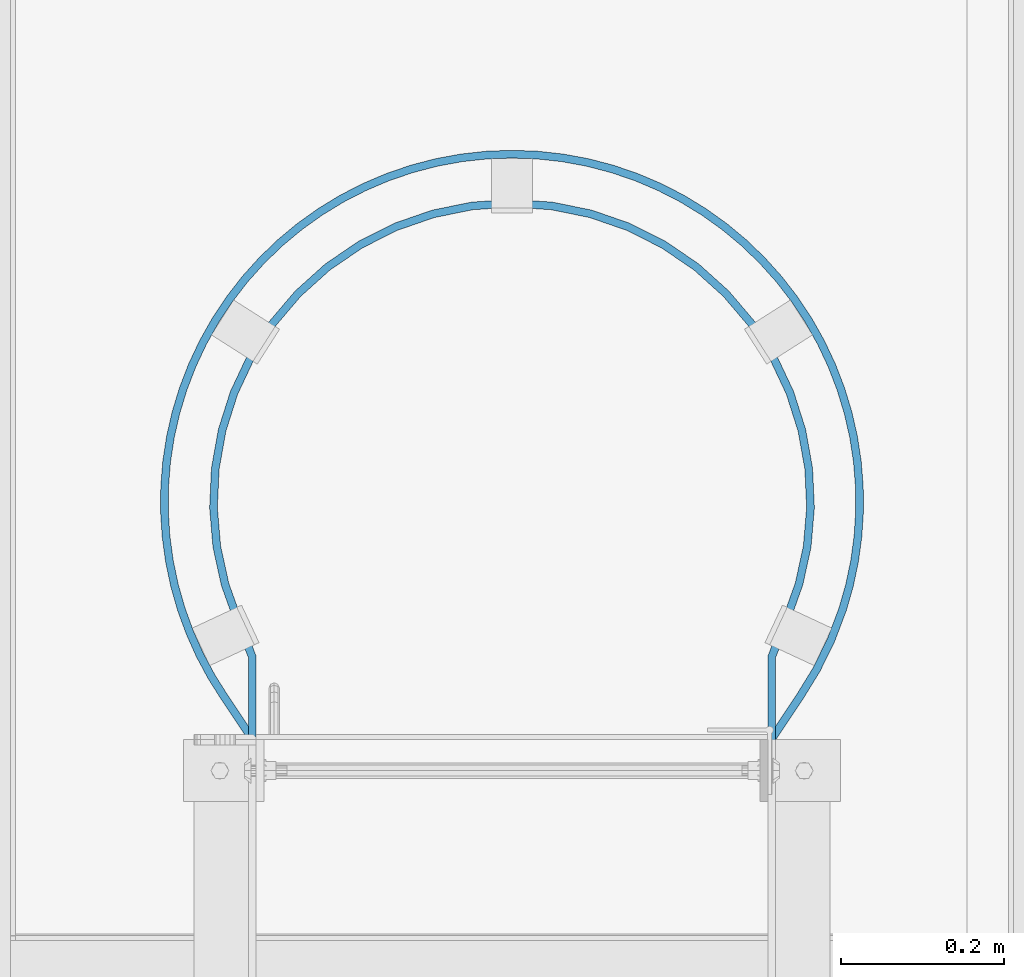
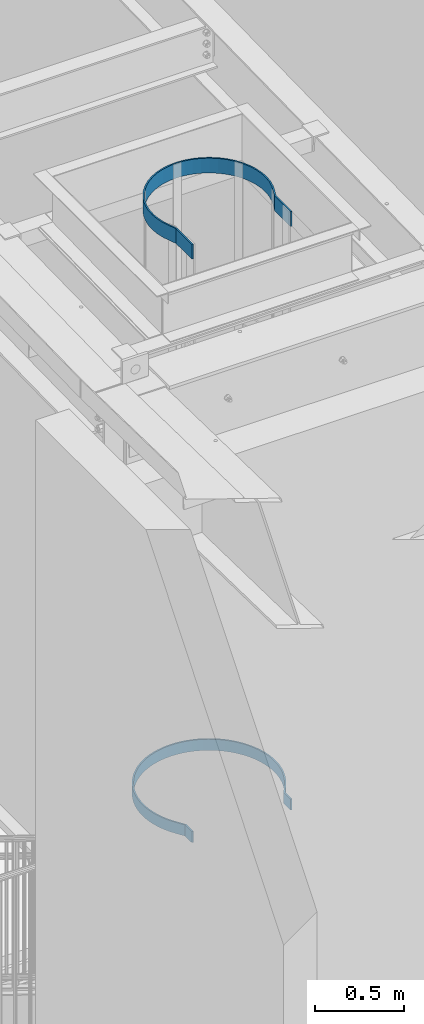
# One storey, part 1078 of 1763: 2 beams, 1 element without a shape of its own.
"""IFC2X3 building model written with IfcOpenShell, lengths in millimetres."""

from ifc_helpers import new_model, si_unit, frame, origin_with_axes, place, context, subcontext, project, spatial, faceted_brep, material, type_object, element, aggregate, save


model = new_model("IFC2X3")

# Units and contexts
model_context = context("Model", 3, precision=1e-05, world=origin_with_axes())
body_context = subcontext(model_context, "Body", "Model", "MODEL_VIEW")
ifc_project = project(units=[si_unit("LENGTHUNIT", "METRE", prefix="MILLI"), si_unit("AREAUNIT", "SQUARE_METRE"), si_unit("VOLUMEUNIT", "CUBIC_METRE"), si_unit("MASSUNIT", "GRAM", prefix="KILO"), si_unit("TIMEUNIT", "SECOND"), si_unit("PLANEANGLEUNIT", "RADIAN"), si_unit("SOLIDANGLEUNIT", "STERADIAN"), si_unit("THERMODYNAMICTEMPERATUREUNIT", "DEGREE_CELSIUS"), si_unit("LUMINOUSINTENSITYUNIT", "LUMEN")], contexts=[model_context])

# Site, building, storey
site_placement = place(None, origin_with_axes())
site = spatial("IfcSite", under=ifc_project, at=site_placement, CompositionType="ELEMENT")
building_placement = place(site_placement, origin_with_axes())
building = spatial("IfcBuilding", under=site, at=building_placement, Name="Undefined", CompositionType="ELEMENT")
storey_placement = place(building_placement, origin_with_axes())
storey = spatial("IfcBuildingStorey", under=building, at=storey_placement, Name="Undefined", CompositionType="ELEMENT", Elevation=0.0)

# Assembly, beams
assembly_placement = place(storey_placement, origin_with_axes())
assembly = element("IfcElementAssembly", 1, at=assembly_placement, inside=storey, Name="LADDER", AssemblyPlace="NOTDEFINED", PredefinedType="RIGID_FRAME")
ifc_material = material(Name="STEEL/A36")
beam_type_1 = type_object("IfcBeamType", PredefinedType="NOTDEFINED")
beam_1_placement = place(assembly_placement, frame((-86091.1497736991, 30492.7, 7658.1), z_axis=(0.0, 0.0, 1.0), x_axis=(0.0, 1.0, 0.0)))
beam_1 = element("IfcBeam", 2, at=beam_1_placement, type_object=beam_type_1, material=ifc_material, Name="PLATE", context=body_context, shape_type="Brep", body=[
    faceted_brep([(0.0, -4.76249999999709, -38.1000000000004), (0.0, -4.76249999999709, 38.1000000000004), (0.0, 4.76249999999709, 38.1000000000004), (0.0, 4.76249999999709, -38.1000000000004), (78.8281400921587, 4.76249999999709, 38.1000000000004), (78.8281400921587, 4.76249999999709, -38.1000000000004), (75.9319917437788, -4.76249999999709, -38.1000000000004), (75.9319917437788, -4.76249999999709, 38.1000000000004), (82.4725334546747, 2.32052630072576, -38.1000000000004), (82.4725334546747, 2.32052630072576, 38.1000000000004), (130.23712785008, -29.6849795318849, 38.1000000000004), (130.23712785008, -29.6849795318849, -38.1000000000004), (77.1704222683657, -5.59232665935997, 38.1000000000004), (77.1704222683657, -5.59232665935997, -38.1000000000004), (124.867288043475, -37.5520276092284, -38.1000000000004), (124.867288043475, -37.5520276092284, 38.1000000000004), (164.34760181994, -50.6686286850454, 38.1000000000004), (164.34760181994, -50.6686286850454, -38.1000000000004), (159.747171460254, -59.0089923165506, -38.1000000000004), (159.747171460254, -59.0089923165506, 38.1000000000004), (196.502852637441, -77.065224005928, -38.1000000000004), (196.502852637441, -77.065224005928, 38.1000000000004), (200.292495644782, -68.3265610145463, 38.1000000000004), (200.292495644782, -68.3265610145463, -38.1000000000004), (234.803737917307, -91.5583185132127, -38.1000000000004), (234.803737917307, -91.5583185132127, 38.1000000000004), (237.748508176443, -82.499954802217, 38.1000000000004), (237.748508176443, -82.499954802217, -38.1000000000004), (266.714984550341, -90.7864578098379, 38.1000000000004), (266.714984550341, -90.7864578098379, -38.1000000000004), (264.42359242673, -100.031734827629, -38.1000000000004), (264.42359242673, -100.031734827629, 38.1000000000004), (294.572231675724, -106.371617841563, -38.1000000000004), (294.572231675724, -106.371617841563, 38.1000000000004), (296.198581312558, -96.9864906789444, 38.1000000000004), (296.198580994936, -96.9864906238945, -38.1000000000004), (326.253675137221, -101.08899552701, 38.1000000000004), (326.253675137221, -101.08899552701, -38.1000000000004), (325.305262653088, -110.566660785917, -38.1000000000004), (325.305262653088, -110.566660785917, 38.1000000000004), (356.260153345538, -112.544614423969, -38.1000000000004), (356.260153345538, -112.544614423969, 38.1000000000004), (356.525735326341, -103.023317704952, 38.1000000000004), (356.52573594483, -103.023317722196, -38.1000000000004), (386.858539739838, -102.77948519589, 38.1000000000004), (386.858539739838, -102.77948519589, -38.1000000000004), (387.277154065716, -112.295281906947, -38.1000000000004), (387.277154065716, -112.295281906947, 38.1000000000004), (418.19623042244, -109.81995243681, -38.1000000000004), (418.19623042244, -109.81995243681, 38.1000000000004), (417.095578659591, -100.35875850069, 38.1000000000004), (417.095578199151, -100.358758554255, -38.1000000000004), (447.080825926212, -95.773625916685, 38.1000000000004), (447.080825926212, -95.773625916685, -38.1000000000004), (448.857836479659, -105.13139586967, -38.1000000000004), (448.857836479659, -105.13139586967, 38.1000000000004), (479.103752236508, -98.2538090848248, -38.1000000000004), (479.103752236508, -98.2538090848248, 38.1000000000004), (476.659553427558, -89.0477503634029, 38.1000000000004), (476.659553185309, -89.0477504277223, -38.1000000000004), (505.679144955247, -80.2158283481549, 38.1000000000004), (505.679144955247, -80.2158283481549, -38.1000000000004), (508.777922306675, -89.2226704099594, -38.1000000000004), (508.777922306675, -89.2226704099594, 38.1000000000004), (537.727203103354, -78.0845843564894, -38.1000000000004), (537.727203103354, -78.0845843564894, 38.1000000000004), (533.989837912271, -69.3234356630419, 38.1000000000004), (533.989838241414, -69.323435522645, -38.1000000000004), (561.867636780938, -56.2093802318414, 38.1000000000004), (561.867636780938, -56.2093802318414, -38.1000000000004), (566.233823613755, -64.6747235527437, -38.1000000000004), (566.233823613755, -64.6747235527437, 38.1000000000004), (593.686873067349, -49.2221549012611, -38.1000000000004), (593.686873067349, -49.2221549012611, 38.1000000000004), (588.715104471717, -41.0976769468689, 38.1000000000004), (588.715104395698, -41.0976769933914, -38.1000000000004), (614.389333853338, -24.0687602890685, 38.1000000000004), (614.389333853338, -24.0687602890685, -38.1000000000004), (619.940221920802, -31.8091263438691, -38.1000000000004), (619.940221920802, -31.8091263438691, 38.1000000000004), (644.85412439784, -12.5283237849653, -38.1000000000004), (644.85412439784, -12.5283237849653, 38.1000000000004), (638.753663688101, -5.21327052959532, 38.1000000000004), (638.753664011791, -5.21327025965729, -38.1000000000004), (661.678428288371, 15.3684290287201, 38.1000000000004), (661.678428288371, 15.3684290287201, -38.1000000000004), (668.295984249875, 8.51762045627402, -38.1000000000004), (668.295984249875, 8.51762045627402, 38.1000000000004), (690.141022654036, 31.2166707885481, -38.1000000000004), (690.141022654036, 31.2166707885481, 38.1000000000004), (683.041594533461, 37.5667688476969, 38.1000000000004), (683.041593505903, 37.5667676988669, -38.1000000000004), (702.729418355568, 61.2635952415876, 38.1000000000004), (702.729418355568, 61.2635952415876, -38.1000000000004), (710.272938379007, 55.4480186875444, -38.1000000000004), (710.272938379007, 55.4480186875444, 38.1000000000004), (728.58456794716, 81.0826900774846, -38.1000000000004), (728.58456794716, 81.0826900774846, 38.1000000000004), (720.637111740347, 86.3327914899128, 38.1000000000004), (720.637112821489, 86.3327931265085, -38.1000000000004), (736.669364110632, 112.640901093167, 38.1000000000004), (736.669364110632, 112.640901093167, -38.1000000000004), (744.978449421364, 107.984214900294, -38.1000000000004), (744.978449421364, 107.984214900294, 38.1000000000004), (759.367321256112, 136.009415674052, -38.1000000000004), (759.367321256112, 136.009415674052, 38.1000000000004), (750.740833040763, 140.047896337681, 38.1000000000004), (750.740833179756, 140.047896634569, -38.1000000000004), (762.776650659987, 168.407908243476, 38.1000000000004), (762.776650659987, 168.407908243476, -38.1000000000004), (771.674618857607, 165.009116258923, -38.1000000000004), (771.674618857607, 165.009116258923, 38.1000000000004), (781.834847400212, 194.828941625077, -38.1000000000004), (781.834847400212, 194.828941625077, 38.1000000000004), (772.712760021663, 197.569953638595, 38.1000000000004), (772.712759065456, 197.569950456324, -38.1000000000004), (780.496208582714, 227.378804487118, 38.1000000000004), (780.496208582714, 227.378804487118, -38.1000000000004), (789.793867980745, 225.310192701843, -38.1000000000004), (789.793867980745, 225.310192701843, 38.1000000000004), (795.509293047762, 256.290612048411, -38.1000000000004), (795.509293047762, 256.290612048411, 38.1000000000004), (786.08555558505, 257.675818615651, 38.1000000000004), (786.085556254031, 257.675823166777, -38.1000000000004), (789.451127014967, 288.299725754827, 38.1000000000004), (789.451127014967, 288.299725754827, -38.1000000000004), (798.950776527548, 287.605258953554, -38.1000000000004), (798.950776527548, 287.605258953554, 38.1000000000004), (800.100024414052, 319.087483116877, -38.1000000000004), (800.100024414052, 319.087483116877, 38.1000000000004), (790.57502441408, 319.087504676092, 38.1000000000004), (790.575024414065, 319.087499519141, -38.1000000000004), (789.451180547781, 349.875281340326, 38.1000000000004), (789.451180547781, 349.875281340326, -38.1000000000004), (798.950830085181, 350.569747802161, -38.1000000000004), (798.950830085181, 350.569747802161, 38.1000000000004), (795.509290042879, 381.884426704419, -38.1000000000004), (795.509290042879, 381.884426704419, 38.1000000000004), (786.085558589933, 380.499179252613, 38.1000000000004), (786.085557796963, 380.499184647124, -38.1000000000004), (780.49616057477, 410.796195315183, 38.1000000000004), (780.49616057477, 410.796195315183, -38.1000000000004), (789.79381986272, 412.864807595266, -38.1000000000004), (789.79381986272, 412.864807595266, 38.1000000000004), (781.834852587352, 443.346044163758, -38.1000000000004), (781.834852587352, 443.346044163758, 38.1000000000004), (772.712754834523, 440.605066676086, 38.1000000000004), (772.712756355115, 440.605061615497, -38.1000000000004), (762.776690761821, 469.767102157362, 38.1000000000004), (762.776690761821, 469.767102157362, -38.1000000000004), (771.674658662254, 473.165894919919, -38.1000000000004), (771.674658662254, 473.165894919919, 38.1000000000004), (759.367315361833, 502.165584709481, -38.1000000000004), (759.367315361833, 502.165584709481, 38.1000000000004), (750.740838935042, 498.127078864738, 38.1000000000004), (750.740836750825, 498.127083530359, -38.1000000000004), (736.669335051971, 525.534090732748, 38.1000000000004), (736.669335051971, 525.534090732748, -38.1000000000004), (744.978421757369, 530.190774437069, -38.1000000000004), (744.978421757369, 530.190774437069, 38.1000000000004), (728.584573261531, 557.092327817692, -38.1000000000004), (728.584573261531, 557.092327817692, 38.1000000000004), (720.637106425966, 551.842242494808, 38.1000000000004), (720.637109588457, 551.842237707504, -38.1000000000004), (702.729433985576, 576.91141988356, 38.1000000000004), (702.729433985576, 576.91141988356, -38.1000000000004), (710.27295161628, 582.726999541279, -38.1000000000004), (710.27295161628, 582.726999541279, 38.1000000000004), (690.141018466191, 606.958317871744, -38.1000000000004), (690.141018466191, 606.958317871744, 38.1000000000004), (683.041598721309, 600.608210448569, 38.1000000000004), (683.04159472778, 600.608214913329, -38.1000000000004), (661.678428323674, 622.806552314461, 38.1000000000004), (661.678428323674, 622.806552314461, -38.1000000000004), (668.295983907858, 629.657361251375, -38.1000000000004), (668.295983907858, 629.657361251375, 38.1000000000004), (644.854123895107, 650.703303414135, -38.1000000000004), (644.854123895107, 650.703303414135, 38.1000000000004), (638.753664190837, 643.38824932024, 38.1000000000004), (638.753666315864, 643.38824754805, -38.1000000000004), (614.389326607528, 662.243732166506, 38.1000000000004), (614.389326607528, 662.243732166506, -38.1000000000004), (619.940215156661, 669.984097875888, -38.1000000000004), (619.940215156661, 669.984097875888, 38.1000000000004), (593.686876567466, 687.397136737651, -38.1000000000004), (593.686876567466, 687.397136737651, 38.1000000000004), (588.715100971596, 679.272663067037, 38.1000000000004), (588.71510224498, 679.272662287796, -38.1000000000004), (561.867635749004, 694.384383251556, 38.1000000000004), (561.867635749004, 694.384383251556, -38.1000000000004), (566.233826729906, 702.849724432992, -38.1000000000004), (566.233826729906, 702.849724432992, 38.1000000000004), (537.727204666015, 716.259602000428, -38.1000000000004), (537.727204666015, 716.259602000428, 38.1000000000004), (533.989836349614, 707.498454640197, 38.1000000000004), (533.989835660912, 707.498454933986, -38.1000000000004), (505.679146541104, 718.390856406841, 38.1000000000004), (505.679146541104, 718.390856406841, -38.1000000000004), (508.77792495233, 727.397698104018, -38.1000000000004), (508.77792495233, 727.397698104018, 38.1000000000004), (479.103751196297, 736.428835300947, -38.1000000000004), (479.103751196297, 736.428835300947, 38.1000000000004), (476.659554467755, 727.222776027178, 38.1000000000004), (476.659553026537, 727.222776409821, -38.1000000000004), (447.080830100353, 733.948642770381, 38.1000000000004), (447.080830100353, 733.948642770381, -38.1000000000004), (448.857834933842, 743.306413809565, -38.1000000000004), (448.857834933842, 743.306413809565, 38.1000000000004), (418.19622468757, 747.994940896941, -38.1000000000004), (418.19622468757, 747.994940896941, 38.1000000000004), (417.095584394458, 738.533745626512, 38.1000000000004), (417.095583392587, 738.533745743058, -38.1000000000004), (386.858536912045, 740.954465386443, 38.1000000000004), (386.858536912045, 740.954465386443, -38.1000000000004), (387.277155969743, 750.470261889335, -38.1000000000004), (387.277155969743, 750.470261889335, 38.1000000000004), (356.260162224666, 750.71963298216, -38.1000000000004), (356.260162224666, 750.71963298216, 38.1000000000004), (356.525726447209, 741.198335767825, 38.1000000000004), (356.525731175392, 741.198335899709, -38.1000000000004), (326.253674065167, 739.264025288183, 38.1000000000004), (326.253674065167, 739.264025288183, -38.1000000000004), (325.305260407538, 748.741690429655, -38.1000000000004), (325.305260407538, 748.741690429655, 38.1000000000004), (294.572226739729, 744.546627667354, -38.1000000000004), (294.572226739729, 744.546627667354, 38.1000000000004), (296.198586248549, 735.161502215444, 38.1000000000004), (296.198581965185, 735.16150147318, -38.1000000000004), (266.71498510032, 728.961470185415, 38.1000000000004), (266.71498510032, 728.961470185415, -38.1000000000004), (264.423595225213, 738.206747760487, -38.1000000000004), (264.423595225213, 738.206747760487, 38.1000000000004), (234.803740750267, 729.73334537413, -38.1000000000004), (234.803740750267, 729.73334537413, 38.1000000000004), (237.748505343487, 720.674979821197, 38.1000000000004), (237.748507129774, 720.674980401891, -38.1000000000004), (209.446597049839, 710.344180542161, 38.1000000000004), (209.446597049839, 710.344180542161, -38.1000000000004), (205.863433560771, 719.169517046263, -38.1000000000004), (205.863433560771, 719.169517046263, 38.1000000000004), (177.750025443856, 706.569040168208, -38.1000000000004), (177.750025443856, 706.569040168208, 38.1000000000004), (181.953343696769, 698.02165807398, 38.1000000000004), (181.953341985391, 698.021657232384, -38.1000000000004), (155.56003714032, 683.85848779064, 38.1000000000004), (155.56003714032, 683.85848779064, -38.1000000000004), (150.761393048178, 692.086406110422, -38.1000000000004), (150.761393048178, 692.086406110422, 38.1000000000004), (124.867293171032, 675.727045605003, -38.1000000000004), (124.867293171032, 675.727045605003, 38.1000000000004), (130.237122722523, 667.859990527795, 38.1000000000004), (130.237125286774, 667.859992278085, -38.1000000000004), (129.753933041753, 667.536011537857, -38.1000000000004), (129.753933041753, 667.536011537857, 38.1000000000004), (78.8281410476739, 633.412487792972, 38.1000000000004), (78.8281410476739, 633.412487792972, -38.1000000000004), (124.451818948983, 675.448862550431, 38.1000000000004), (124.451818948983, 675.448862550431, -38.1000000000004), (75.9319907882636, 642.937487792966, -38.1000000000004), (75.9319907882636, 642.937487792966, 38.1000000000004), (0.0, 633.412487792972, 38.1000000000004), (0.0, 633.412487792972, -38.1000000000004), (0.0, 642.937487792966, 38.1000000000004), (0.0, 642.937487792966, -38.1000000000004)], [[[0, 1, 2, 3]], [[3, 2, 4, 5]], [[1, 0, 6, 7]], [[8, 5, 4, 9, 10, 11]], [[12, 7, 6, 13, 14, 15]], [[11, 10, 16, 17]], [[15, 14, 18, 19]], [[18, 20, 21, 19]], [[16, 22, 23, 17]], [[20, 24, 25, 21]], [[22, 26, 27, 23]], [[27, 26, 28, 29]], [[25, 24, 30, 31]], [[30, 32, 33, 31]], [[28, 34, 35, 29]], [[35, 34, 36, 37]], [[33, 32, 38, 39]], [[38, 40, 41, 39]], [[36, 42, 43, 37]], [[43, 42, 44, 45]], [[41, 40, 46, 47]], [[46, 48, 49, 47]], [[44, 50, 51, 45]], [[51, 50, 52, 53]], [[49, 48, 54, 55]], [[54, 56, 57, 55]], [[52, 58, 59, 53]], [[59, 58, 60, 61]], [[57, 56, 62, 63]], [[62, 64, 65, 63]], [[60, 66, 67, 61]], [[67, 66, 68, 69]], [[65, 64, 70, 71]], [[70, 72, 73, 71]], [[68, 74, 75, 69]], [[75, 74, 76, 77]], [[73, 72, 78, 79]], [[78, 80, 81, 79]], [[76, 82, 83, 77]], [[83, 82, 84, 85]], [[81, 80, 86, 87]], [[86, 88, 89, 87]], [[84, 90, 91, 85]], [[91, 90, 92, 93]], [[89, 88, 94, 95]], [[94, 96, 97, 95]], [[92, 98, 99, 93]], [[99, 98, 100, 101]], [[97, 96, 102, 103]], [[102, 104, 105, 103]], [[100, 106, 107, 101]], [[107, 106, 108, 109]], [[105, 104, 110, 111]], [[110, 112, 113, 111]], [[108, 114, 115, 109]], [[115, 114, 116, 117]], [[113, 112, 118, 119]], [[118, 120, 121, 119]], [[116, 122, 123, 117]], [[123, 122, 124, 125]], [[121, 120, 126, 127]], [[126, 128, 129, 127]], [[124, 130, 131, 125]], [[131, 130, 132, 133]], [[129, 128, 134, 135]], [[134, 136, 137, 135]], [[132, 138, 139, 133]], [[139, 138, 140, 141]], [[137, 136, 142, 143]], [[142, 144, 145, 143]], [[140, 146, 147, 141]], [[147, 146, 148, 149]], [[145, 144, 150, 151]], [[150, 152, 153, 151]], [[148, 154, 155, 149]], [[155, 154, 156, 157]], [[153, 152, 158, 159]], [[158, 160, 161, 159]], [[156, 162, 163, 157]], [[163, 162, 164, 165]], [[161, 160, 166, 167]], [[166, 168, 169, 167]], [[164, 170, 171, 165]], [[171, 170, 172, 173]], [[169, 168, 174, 175]], [[174, 176, 177, 175]], [[172, 178, 179, 173]], [[179, 178, 180, 181]], [[177, 176, 182, 183]], [[182, 184, 185, 183]], [[180, 186, 187, 181]], [[187, 186, 188, 189]], [[185, 184, 190, 191]], [[190, 192, 193, 191]], [[188, 194, 195, 189]], [[195, 194, 196, 197]], [[193, 192, 198, 199]], [[198, 200, 201, 199]], [[196, 202, 203, 197]], [[203, 202, 204, 205]], [[201, 200, 206, 207]], [[206, 208, 209, 207]], [[204, 210, 211, 205]], [[211, 210, 212, 213]], [[209, 208, 214, 215]], [[214, 216, 217, 215]], [[212, 218, 219, 213]], [[219, 218, 220, 221]], [[217, 216, 222, 223]], [[222, 224, 225, 223]], [[220, 226, 227, 221]], [[227, 226, 228, 229]], [[225, 224, 230, 231]], [[230, 232, 233, 231]], [[228, 234, 235, 229]], [[235, 234, 236, 237]], [[233, 232, 238, 239]], [[238, 240, 241, 239]], [[236, 242, 243, 237]], [[243, 242, 244, 245]], [[241, 240, 246, 247]], [[246, 248, 249, 247]], [[244, 250, 251, 245]], [[252, 251, 250, 253, 254, 255]], [[256, 249, 248, 257, 258, 259]], [[255, 254, 260, 261]], [[254, 253, 250, 244, 242, 236, 234, 228, 226, 220, 218, 212, 210, 204, 202, 196, 194, 188, 186, 180, 178, 172, 170, 164, 162, 156, 154, 148, 146, 140, 138, 132, 130, 124, 122, 116, 114, 108, 106, 100, 98, 92, 90, 84, 82, 76, 74, 68, 66, 60, 58, 52, 50, 44, 42, 36, 34, 28, 26, 22, 16, 10, 9, 4, 2, 1, 7, 12, 15, 19, 21, 25, 31, 33, 39, 41, 47, 49, 55, 57, 63, 65, 71, 73, 79, 81, 87, 89, 95, 97, 103, 105, 111, 113, 119, 121, 127, 129, 135, 137, 143, 145, 151, 153, 159, 161, 167, 169, 175, 177, 183, 185, 191, 193, 199, 201, 207, 209, 215, 217, 223, 225, 231, 233, 239, 241, 247, 249, 256, 259, 262, 260]], [[259, 258, 263, 262]], [[258, 257, 248, 246, 240, 238, 232, 230, 224, 222, 216, 214, 208, 206, 200, 198, 192, 190, 184, 182, 176, 174, 168, 166, 160, 158, 152, 150, 144, 142, 136, 134, 128, 126, 120, 118, 112, 110, 104, 102, 96, 94, 88, 86, 80, 78, 72, 70, 64, 62, 56, 54, 48, 46, 40, 38, 32, 30, 24, 20, 18, 14, 13, 6, 0, 3, 5, 8, 11, 17, 23, 27, 29, 35, 37, 43, 45, 51, 53, 59, 61, 67, 69, 75, 77, 83, 85, 91, 93, 99, 101, 107, 109, 115, 117, 123, 125, 131, 133, 139, 141, 147, 149, 155, 157, 163, 165, 171, 173, 179, 181, 187, 189, 195, 197, 203, 205, 211, 213, 219, 221, 227, 229, 235, 237, 243, 245, 251, 252, 255, 261, 263]], [[262, 263, 261, 260]]]),
])
beam_type_2 = type_object("IfcBeamType", PredefinedType="NOTDEFINED")
beam_2_placement = place(assembly_placement, frame((-86091.1497736991, 30492.7, 11661.2774622366), z_axis=(0.0, 0.0, 1.0), x_axis=(0.0, 1.0, 0.0)))
beam_2 = element("IfcBeam", 3, at=beam_2_placement, type_object=beam_type_2, material=ifc_material, Name="PLATE", context=body_context, shape_type="Brep", body=[
    faceted_brep([(0.0, -4.76249999999709, -50.7999999999993), (0.0, -4.76249999999999, 50.7999992370605), (0.0, 4.76249999999999, 50.7999992370605), (0.0, 4.76249999999709, -50.7999999999993), (178.996850182604, 4.76249999999709, 50.7999999999993), (178.996850182604, 4.76249999999709, -50.7999999999993), (177.198920081068, -4.76249999999709, -50.7999999999993), (177.198920081068, -4.76249999999709, 50.7999999999993), (223.923672469686, -12.8248261728149, 50.7999999999993), (223.923672469686, -12.8248261728149, -50.7999999999993), (220.301876254001, -21.6358444885554, -50.7999999999993), (220.301876254001, -21.6358444885554, 50.7999999999993), (225.062862920662, -13.315718922473, 50.7999999999993), (225.062862920662, -13.315718922473, -50.7999999999993), (221.293479549164, -22.0631399137492, -50.7999999999993), (221.293479549164, -22.0631399137492, 50.7999999999993), (268.797622331076, -28.9179700700479, 50.7999999999993), (268.797622331076, -28.9179700700479, -50.7999999999993), (266.179279316701, -38.0760214380571, -50.7999999999993), (266.179279316701, -38.0760214380571, 50.7999999999993), (312.745907862791, -48.2099496661976, -50.7999999999993), (312.745907862791, -48.2099496661976, 50.7999999999993), (314.170107762209, -38.7920263469859, 50.7999999999993), (314.170241653486, -38.7920465962816, -50.7999999999993), (361.121282329259, -42.7913046950562, 50.7999999999993), (361.121282318767, -42.7913046948524, -50.7999999999993), (360.932367573077, -52.3144310837524, -50.7999999999993), (360.932367573077, -52.3144310837524, 50.7999999999993), (408.553266824139, -40.6172059538658, 50.7999999999993), (408.55326734237, -40.6172058958764, -50.7999999999993), (409.612565695392, -50.0831190583413, -50.7999999999993), (409.612565695392, -50.0831190583413, 50.7999999999993), (455.29255648837, -32.2529272571555, 50.7999999999993), (455.292556022912, -32.2529273724067, -50.7999999999993), (457.581833160064, -41.4987283214577, -50.7999999999993), (457.581833160064, -41.4987283214577, 50.7999999999993), (500.534787634006, -17.8424056936346, 50.7999999999993), (500.534787766108, -17.8424056417862, -50.7999999999993), (504.014650842557, -26.7089820932306, -50.7999999999993), (504.014650842557, -26.7089820932306, 50.7999999999993), (543.501358126799, 2.36636306563742, 50.7999999999993), (543.501358463509, 2.36636325190193, -50.7999999999993), (548.111923123197, -5.96840240281017, -50.7999999999993), (548.111923123197, -5.96840240281017, 50.7999999999993), (584.009198027747, 28.437626318133, 50.7999999999993), (584.009196713676, 28.4376253428782, -50.7999999999993), (589.685748261316, 20.7889399965643, -50.7999999999993), (589.685748261316, 20.7889399965643, 50.7999999999993), (620.696023637076, 59.6572758920083, 50.7999999999993), (620.696025797544, 59.6572779939015, -50.7999999999993), (627.338033980115, 52.8301737539878, -50.7999999999993), (627.338033980115, 52.8301737539878, 50.7999999999993), (652.912087062563, 95.4723277354788, 50.7999999999993), (652.91208579253, 95.4723261190084, -50.7999999999993), (660.401877781187, 89.5877155994822, -50.7999999999993), (660.401877781187, 89.5877155994822, 50.7999999999993), (680.086755434721, 135.248364146639, 50.7999999999993), (680.086754505715, 135.248362571074, -50.7999999999993), (688.291662534022, 130.410479847502, -50.7999999999993), (688.291662534022, 130.410479847502, 50.7999999999993), (701.738563283165, 178.280798617299, 50.7999999999993), (701.73856488548, 178.280802411682, -50.7999999999993), (710.513267771523, 174.575372037012, -50.7999999999993), (710.513267771523, 174.575372037012, 50.7999999999993), (717.484088221368, 223.807419031116, 50.7999999999993), (717.484087259192, 223.80741550494, -50.7999999999993), (726.673138341132, 221.300033361462, -50.7999999999993), (726.673138341132, 221.300033361462, 50.7999999999993), (727.044327443258, 271.021749271633, 50.7999999999993), (727.044327941214, 271.021752988236, -50.7999999999993), (736.484969431742, 269.756876216648, -50.7999999999993), (736.484969431742, 269.756876216648, 50.7999999999993), (730.250012207038, 319.087498404828, 50.7999999999993), (730.250012207031, 319.087495313172, -50.7999999999993), (739.775012207032, 319.087489388141, -50.7999999999993), (739.775012207032, 319.087489388141, 50.7999999999993), (727.044328675405, 367.153259842584, 50.7999999999993), (727.044328513592, 367.153261050305, -50.7999999999993), (736.484968199595, 368.418151290229, -50.7999999999993), (736.484968199595, 368.418151290229, 50.7999999999993), (717.484085293047, 414.367594752388, 50.7999999999993), (717.484085562104, 414.367593766336, -50.7999999999993), (726.673141269457, 416.87495895855, -50.7999999999993), (726.673141269457, 416.87495895855, 50.7999999999993), (701.738568815384, 459.894191333835, 50.7999999999993), (701.738567727607, 459.894193909757, -50.7999999999993), (710.513262239299, 463.599644115384, -50.7999999999993), (710.513262239299, 463.599644115384, 50.7999999999993), (680.086748702986, 502.926650321984, 50.7999999999993), (680.086750557224, 502.926647177228, -50.7999999999993), (688.29166926576, 507.764511787405, -50.7999999999993), (688.29166926576, 507.764511787405, 50.7999999999993), (652.912093282088, 542.702644512043, 50.7999999999993), (652.912090596754, 542.702647929866, -50.7999999999993), (660.401871561658, 548.58727248013, -50.7999999999993), (660.401871561658, 548.58727248013, 50.7999999999993), (620.696019913037, 578.51772696813, 50.7999999999993), (620.696024247423, 578.517722751247, -50.7999999999993), (627.338037704154, 585.344821859995, -50.7999999999993), (627.338037704154, 585.344821859995, 50.7999999999993), (584.009197168081, 609.737364020199, 50.7999999999993), (584.009193942664, 609.737366413974, -50.7999999999993), (589.685749120978, 617.386049065753, -50.7999999999993), (589.685749120978, 617.386049065753, 50.7999999999993), (543.501362367231, 635.808628103681, 50.7999999999993), (543.501361835584, 635.808628397775, -50.7999999999993), (548.111918882772, 644.143398263506, -50.7999999999993), (548.111918882772, 644.143398263506, 50.7999999999993), (500.534784456919, 656.017396640862, 50.7999999999993), (500.534786494096, 656.017395841336, -50.7999999999993), (504.014654019651, 664.883970546623, -50.7999999999993), (504.014654019651, 664.883970546623, 50.7999999999993), (455.292552670799, 670.427942698254, 50.7999999999993), (455.292552716117, 670.427942687034, -50.7999999999993), (457.581836977639, 679.673741872059, -50.7999999999993), (457.581836977639, 679.673741872059, 50.7999999999993), (408.553277115458, 678.792188780484, 50.7999999999993), (408.553273513717, 678.792189183543, -50.7999999999993), (409.61255540407, 688.258104188266, -50.7999999999993), (409.61255540407, 688.258104188266, 50.7999999999993), (361.121277097478, 680.966280940163, 50.7999999999993), (361.12128097919, 680.966281017158, -50.7999999999993), (360.932372804862, 690.489407536414, -50.7999999999993), (360.932372804862, 690.489407536414, 50.7999999999993), (314.170242988643, 676.96702314711, 50.7999999999993), (314.170241809003, 676.967022968674, -50.7999999999993), (312.745772636365, 686.384905563842, -50.7999999999993), (312.745772636365, 686.384905563842, 50.7999999999993), (268.136629496974, 666.902248529776, 50.7999999999993), (268.136630694469, 666.902248874627, -50.7999999999993), (265.500760639741, 676.055271001474, -50.7999999999993), (265.500760639741, 676.055271001474, 50.7999999999993), (225.062605304865, 651.49063320244, 50.7999999999993), (225.062857896504, 651.490742038819, -50.7999999999993), (221.293731963044, 660.238273954848, -50.7999999999993), (221.293731963044, 660.238273954848, 50.7999999999993), (223.923670069664, 650.999851168279, 50.7999999999993), (223.923670069664, 650.999851168279, -50.7999999999993), (220.301873029879, 659.81086903195, -50.7999999999993), (220.301873029879, 659.81086903195, 50.7999999999993), (178.996852032531, 633.412487792972, 50.7999999999993), (178.996852032531, 633.412487792972, -50.7999999999993), (177.198918231141, 642.937487792966, -50.7999999999993), (177.198918231141, 642.937487792966, 50.7999999999993), (0.0, 633.412487792972, 50.7999999999993), (0.0, 633.412487792972, -50.7999999999993), (0.0, 642.937487792966, 50.7999999999993), (0.0, 642.937487792966, -50.7999999999993)], [[[0, 1, 2, 3]], [[3, 2, 4, 5]], [[1, 0, 6, 7]], [[5, 4, 8, 9]], [[7, 6, 10, 11]], [[9, 8, 12, 13]], [[11, 10, 14, 15]], [[13, 12, 16, 17]], [[15, 14, 18, 19]], [[18, 20, 21, 19]], [[16, 22, 23, 17]], [[23, 22, 24, 25]], [[21, 20, 26, 27]], [[25, 24, 28, 29]], [[27, 26, 30, 31]], [[29, 28, 32, 33]], [[31, 30, 34, 35]], [[33, 32, 36, 37]], [[35, 34, 38, 39]], [[37, 36, 40, 41]], [[39, 38, 42, 43]], [[41, 40, 44, 45]], [[43, 42, 46, 47]], [[45, 44, 48, 49]], [[47, 46, 50, 51]], [[49, 48, 52, 53]], [[51, 50, 54, 55]], [[53, 52, 56, 57]], [[55, 54, 58, 59]], [[57, 56, 60, 61]], [[59, 58, 62, 63]], [[61, 60, 64, 65]], [[63, 62, 66, 67]], [[65, 64, 68, 69]], [[67, 66, 70, 71]], [[69, 68, 72, 73]], [[71, 70, 74, 75]], [[73, 72, 76, 77]], [[75, 74, 78, 79]], [[77, 76, 80, 81]], [[79, 78, 82, 83]], [[81, 80, 84, 85]], [[83, 82, 86, 87]], [[85, 84, 88, 89]], [[87, 86, 90, 91]], [[89, 88, 92, 93]], [[91, 90, 94, 95]], [[93, 92, 96, 97]], [[95, 94, 98, 99]], [[97, 96, 100, 101]], [[99, 98, 102, 103]], [[101, 100, 104, 105]], [[103, 102, 106, 107]], [[105, 104, 108, 109]], [[107, 106, 110, 111]], [[109, 108, 112, 113]], [[111, 110, 114, 115]], [[113, 112, 116, 117]], [[115, 114, 118, 119]], [[117, 116, 120, 121]], [[119, 118, 122, 123]], [[121, 120, 124, 125]], [[123, 122, 126, 127]], [[125, 124, 128, 129]], [[127, 126, 130, 131]], [[129, 128, 132, 133]], [[131, 130, 134, 135]], [[133, 132, 136, 137]], [[135, 134, 138, 139]], [[137, 136, 140, 141]], [[139, 138, 142, 143]], [[141, 140, 144, 145]], [[140, 136, 132, 128, 124, 120, 116, 112, 108, 104, 100, 96, 92, 88, 84, 80, 76, 72, 68, 64, 60, 56, 52, 48, 44, 40, 36, 32, 28, 24, 22, 16, 12, 8, 4, 2, 1, 7, 11, 15, 19, 21, 27, 31, 35, 39, 43, 47, 51, 55, 59, 63, 67, 71, 75, 79, 83, 87, 91, 95, 99, 103, 107, 111, 115, 119, 123, 127, 131, 135, 139, 143, 146, 144]], [[143, 142, 147, 146]], [[142, 138, 134, 130, 126, 122, 118, 114, 110, 106, 102, 98, 94, 90, 86, 82, 78, 74, 70, 66, 62, 58, 54, 50, 46, 42, 38, 34, 30, 26, 20, 18, 14, 10, 6, 0, 3, 5, 9, 13, 17, 23, 25, 29, 33, 37, 41, 45, 49, 53, 57, 61, 65, 69, 73, 77, 81, 85, 89, 93, 97, 101, 105, 109, 113, 117, 121, 125, 129, 133, 137, 141, 145, 147]], [[146, 147, 145, 144]]]),
])
aggregate(assembly, [beam_1, beam_2])

save(model, "model.ifc")
